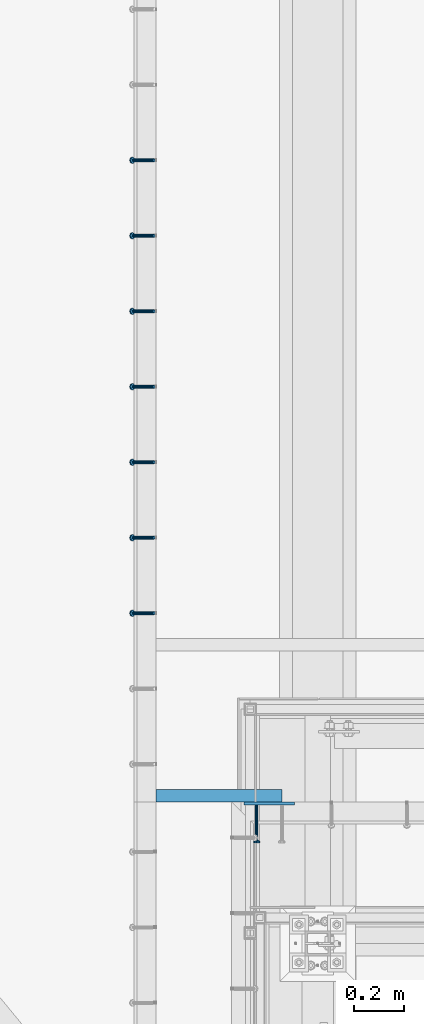
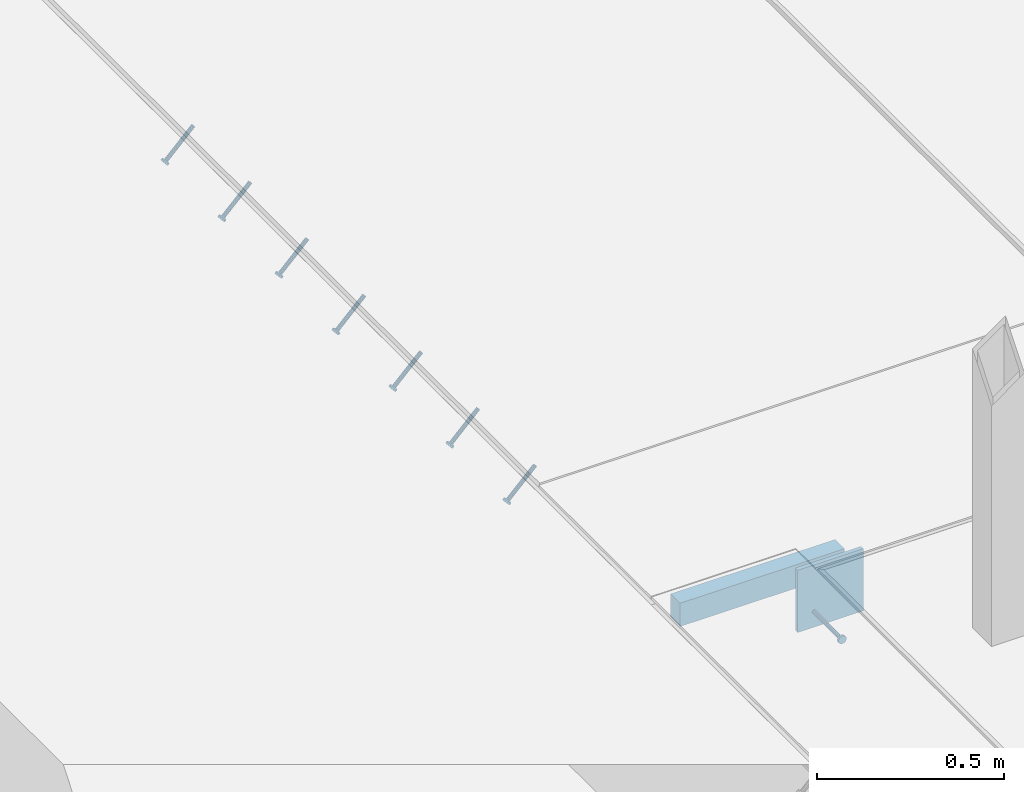
# One storey, part 2118 of 3843: 7 members, 3 beams, 3 elements without a shape of their own.
"""IFC2X3 building model written with IfcOpenShell, lengths in millimetres."""

from ifc_helpers import new_model, si_unit, frame, origin_with_axes, place, context, subcontext, project, spatial, faceted_brep, material, type_object, element, aggregate, save


model = new_model("IFC2X3")

# Units and contexts
model_context = context("Model", 3, precision=1e-05, world=origin_with_axes())
body_context = subcontext(model_context, "Body", "Model", "MODEL_VIEW")
ifc_project = project(units=[si_unit("LENGTHUNIT", "METRE", prefix="MILLI"), si_unit("AREAUNIT", "SQUARE_METRE"), si_unit("VOLUMEUNIT", "CUBIC_METRE"), si_unit("MASSUNIT", "GRAM", prefix="KILO"), si_unit("TIMEUNIT", "SECOND"), si_unit("PLANEANGLEUNIT", "RADIAN"), si_unit("SOLIDANGLEUNIT", "STERADIAN"), si_unit("THERMODYNAMICTEMPERATUREUNIT", "DEGREE_CELSIUS"), si_unit("LUMINOUSINTENSITYUNIT", "LUMEN")], contexts=[model_context])

# Site, building, storey
site_placement = place(None, origin_with_axes())
site = spatial("IfcSite", under=ifc_project, at=site_placement, CompositionType="ELEMENT")
building_placement = place(site_placement, origin_with_axes())
building = spatial("IfcBuilding", under=site, at=building_placement, Name="Undefined", CompositionType="ELEMENT")
storey_placement = place(building_placement, origin_with_axes())
storey = spatial("IfcBuildingStorey", under=building, at=storey_placement, Name="Undefined", CompositionType="ELEMENT", Elevation=0.0)

# Assembly, members
assembly_1_placement = place(storey_placement, origin_with_axes())
assembly_1 = element("IfcElementAssembly", 1, at=assembly_1_placement, inside=storey, Name="EMBED_ANGLE", AssemblyPlace="NOTDEFINED", PredefinedType="RIGID_FRAME")
ifc_material_1 = material(Name="STEEL/A108")
member_type = type_object("IfcMemberType", PredefinedType="NOTDEFINED")
member_1_placement = place(assembly_1_placement, frame((48335.3741210938, 28930.6003845215, 30446.6625), z_axis=(0.0, -1.0, 0.0), x_axis=(-0.707106781186548, 0.0, -0.707106781186548)))
member_1 = element("IfcMember", 2, at=member_1_placement, type_object=member_type, material=ifc_material_1, Name="HEADED STUD ANCHOR", context=body_context, shape_type="Brep", body=[
    faceted_brep([(7.27595761418343e-12, -3.18000006675175, 5.5), (0.0, -5.49999999998363, 3.1800000667572), (118.110000000976, -5.49999999999091, 3.1800000667572), (118.110000000983, -3.18000006675175, 5.5), (0.0, -6.3499999046162, 0.0), (118.110000000968, -6.34999990461256, 0.0), (0.0, -5.49999999998363, -3.1800000667572), (118.110000000976, -5.49999999999091, -3.1800000667572), (7.27595761418343e-12, -3.18000006675175, -5.5), (118.110000000983, -3.18000006675175, -5.5), (7.27595761418343e-12, -1.81898940354586e-12, -6.34999990463257), (118.110000000968, -1.81898940354586e-12, -6.34999990463257), (0.0, 3.18000006675175, -5.5), (118.110000000968, 3.18000006674811, -5.5), (7.27595761418343e-12, 5.49999999998363, -3.1800000667572), (118.110000000983, 5.49999999998363, -3.1800000667572), (7.27595761418343e-12, 6.3499999046162, 0.0), (118.110000000976, 6.34999990461256, 0.0), (7.27595761418343e-12, 5.49999999998363, 3.1800000667572), (118.110000000983, 5.49999999998363, 3.1800000667572), (0.0, 3.18000006675175, 5.5), (118.110000000968, 3.18000006674811, 5.5), (7.27595761418343e-12, -1.81898940354586e-12, 6.34999990463257), (118.110000000968, -1.81898940354586e-12, 6.34999990463257), (120.650000000991, -10.9899997710909, 6.34999990463257), (120.650000000998, -6.34000015257152, 10.9899997711182), (120.650000000991, -12.6999998092379, 0.0), (120.650000000991, -10.9899997710909, -6.34999990463257), (120.650000000998, -6.34000015257152, -10.9899997711182), (120.650000000991, -1.81898940354586e-12, -12.6899995803833), (120.650000000991, 6.34000015257152, -10.9899997711182), (120.650000000998, 10.9899997710909, -6.34999990463257), (120.650000000991, 12.6999998092342, 0.0), (120.650000000998, 10.9899997710909, 6.34999990463257), (120.650000000991, 6.34000015257152, 10.9899997711182), (120.650000000991, -1.81898940354586e-12, 12.6899995803833), (127.000000001048, -10.9899997710945, 6.34999990463257), (127.000000001048, -6.34000015257152, 10.9899997711182), (127.000000001048, -12.6999998092342, 0.0), (127.000000001048, -10.9899997710945, -6.34999990463257), (127.000000001048, -6.34000015257152, -10.9899997711182), (127.000000001048, 1.81898940354586e-12, -12.6899995803833), (127.000000001048, 6.34000015256788, -10.9899997711182), (127.000000001048, 10.9899997710909, -6.34999990463257), (127.000000001048, 12.6999998092379, 0.0), (127.000000001048, 10.9899997710909, 6.34999990463257), (127.000000001048, 6.34000015256788, 10.9899997711182), (127.000000001048, 1.81898940354586e-12, 12.6899995803833)], [[[0, 1, 2, 3]], [[1, 4, 5, 2]], [[4, 6, 7, 5]], [[6, 8, 9, 7]], [[8, 10, 11, 9]], [[10, 12, 13, 11]], [[12, 14, 15, 13]], [[14, 16, 17, 15]], [[16, 18, 19, 17]], [[18, 20, 21, 19]], [[20, 22, 23, 21]], [[22, 0, 3, 23]], [[22, 20, 18, 16, 14, 12, 10, 8, 6, 4, 1, 0]], [[3, 2, 24, 25]], [[2, 5, 26, 24]], [[5, 7, 27, 26]], [[7, 9, 28, 27]], [[9, 11, 29, 28]], [[11, 13, 30, 29]], [[13, 15, 31, 30]], [[15, 17, 32, 31]], [[17, 19, 33, 32]], [[19, 21, 34, 33]], [[21, 23, 35, 34]], [[23, 3, 25, 35]], [[25, 24, 36, 37]], [[24, 26, 38, 36]], [[26, 27, 39, 38]], [[27, 28, 40, 39]], [[28, 29, 41, 40]], [[29, 30, 42, 41]], [[30, 31, 43, 42]], [[31, 32, 44, 43]], [[32, 33, 45, 44]], [[33, 34, 46, 45]], [[34, 35, 47, 46]], [[35, 25, 37, 47]], [[38, 39, 40, 41, 42, 43, 44, 45, 46, 47, 37, 36]]]),
])
member_2_placement = place(assembly_1_placement, frame((48335.3741210938, 29235.4003845215, 30446.6625), z_axis=(0.0, -1.0, 0.0), x_axis=(-0.707106781186548, 0.0, -0.707106781186548)))
member_2 = element("IfcMember", 3, at=member_2_placement, type_object=member_type, material=ifc_material_1, Name="HEADED STUD ANCHOR", context=body_context, shape_type="Brep", body=[
    faceted_brep([(7.27595761418343e-12, -3.18000006675175, 5.5), (0.0, -5.49999999998363, 3.1800000667572), (118.110000000976, -5.49999999999091, 3.1800000667572), (118.110000000983, -3.18000006675175, 5.5), (0.0, -6.3499999046162, 0.0), (118.110000000968, -6.34999990461256, 0.0), (0.0, -5.49999999998363, -3.1800000667572), (118.110000000976, -5.49999999999091, -3.1800000667572), (7.27595761418343e-12, -3.18000006675175, -5.5), (118.110000000983, -3.18000006675175, -5.5), (7.27595761418343e-12, -1.81898940354586e-12, -6.34999990463257), (118.110000000968, -1.81898940354586e-12, -6.34999990463257), (0.0, 3.18000006675175, -5.5), (118.110000000968, 3.18000006674811, -5.5), (7.27595761418343e-12, 5.49999999998363, -3.1800000667572), (118.110000000983, 5.49999999998363, -3.1800000667572), (7.27595761418343e-12, 6.3499999046162, 0.0), (118.110000000976, 6.34999990461256, 0.0), (7.27595761418343e-12, 5.49999999998363, 3.1800000667572), (118.110000000983, 5.49999999998363, 3.1800000667572), (0.0, 3.18000006675175, 5.5), (118.110000000968, 3.18000006674811, 5.5), (7.27595761418343e-12, -1.81898940354586e-12, 6.34999990463257), (118.110000000968, -1.81898940354586e-12, 6.34999990463257), (120.650000000991, -10.9899997710909, 6.34999990463257), (120.650000000998, -6.34000015257152, 10.9899997711182), (120.650000000991, -12.6999998092379, 0.0), (120.650000000991, -10.9899997710909, -6.34999990463257), (120.650000000998, -6.34000015257152, -10.9899997711182), (120.650000000991, -1.81898940354586e-12, -12.6899995803833), (120.650000000991, 6.34000015257152, -10.9899997711182), (120.650000000998, 10.9899997710909, -6.34999990463257), (120.650000000991, 12.6999998092342, 0.0), (120.650000000998, 10.9899997710909, 6.34999990463257), (120.650000000991, 6.34000015257152, 10.9899997711182), (120.650000000991, -1.81898940354586e-12, 12.6899995803833), (127.000000001048, -10.9899997710945, 6.34999990463257), (127.000000001048, -6.34000015257152, 10.9899997711182), (127.000000001048, -12.6999998092342, 0.0), (127.000000001048, -10.9899997710945, -6.34999990463257), (127.000000001048, -6.34000015257152, -10.9899997711182), (127.000000001048, 1.81898940354586e-12, -12.6899995803833), (127.000000001048, 6.34000015256788, -10.9899997711182), (127.000000001048, 10.9899997710909, -6.34999990463257), (127.000000001048, 12.6999998092379, 0.0), (127.000000001048, 10.9899997710909, 6.34999990463257), (127.000000001048, 6.34000015256788, 10.9899997711182), (127.000000001048, 1.81898940354586e-12, 12.6899995803833)], [[[0, 1, 2, 3]], [[1, 4, 5, 2]], [[4, 6, 7, 5]], [[6, 8, 9, 7]], [[8, 10, 11, 9]], [[10, 12, 13, 11]], [[12, 14, 15, 13]], [[14, 16, 17, 15]], [[16, 18, 19, 17]], [[18, 20, 21, 19]], [[20, 22, 23, 21]], [[22, 0, 3, 23]], [[22, 20, 18, 16, 14, 12, 10, 8, 6, 4, 1, 0]], [[3, 2, 24, 25]], [[2, 5, 26, 24]], [[5, 7, 27, 26]], [[7, 9, 28, 27]], [[9, 11, 29, 28]], [[11, 13, 30, 29]], [[13, 15, 31, 30]], [[15, 17, 32, 31]], [[17, 19, 33, 32]], [[19, 21, 34, 33]], [[21, 23, 35, 34]], [[23, 3, 25, 35]], [[25, 24, 36, 37]], [[24, 26, 38, 36]], [[26, 27, 39, 38]], [[27, 28, 40, 39]], [[28, 29, 41, 40]], [[29, 30, 42, 41]], [[30, 31, 43, 42]], [[31, 32, 44, 43]], [[32, 33, 45, 44]], [[33, 34, 46, 45]], [[34, 35, 47, 46]], [[35, 25, 37, 47]], [[38, 39, 40, 41, 42, 43, 44, 45, 46, 47, 37, 36]]]),
])
member_3_placement = place(assembly_1_placement, frame((48335.3741210938, 29540.2003845215, 30446.6625), z_axis=(0.0, -1.0, 0.0), x_axis=(-0.707106781186548, 0.0, -0.707106781186548)))
member_3 = element("IfcMember", 4, at=member_3_placement, type_object=member_type, material=ifc_material_1, Name="HEADED STUD ANCHOR", context=body_context, shape_type="Brep", body=[
    faceted_brep([(7.27595761418343e-12, -3.18000006675175, 5.5), (0.0, -5.49999999998363, 3.1800000667572), (118.110000000976, -5.49999999999091, 3.1800000667572), (118.110000000983, -3.18000006675175, 5.5), (0.0, -6.3499999046162, 0.0), (118.110000000968, -6.34999990461256, 0.0), (0.0, -5.49999999998363, -3.1800000667572), (118.110000000976, -5.49999999999091, -3.1800000667572), (7.27595761418343e-12, -3.18000006675175, -5.5), (118.110000000983, -3.18000006675175, -5.5), (7.27595761418343e-12, -1.81898940354586e-12, -6.34999990463257), (118.110000000968, -1.81898940354586e-12, -6.34999990463257), (0.0, 3.18000006675175, -5.5), (118.110000000968, 3.18000006674811, -5.5), (7.27595761418343e-12, 5.49999999998363, -3.1800000667572), (118.110000000983, 5.49999999998363, -3.1800000667572), (7.27595761418343e-12, 6.3499999046162, 0.0), (118.110000000976, 6.34999990461256, 0.0), (7.27595761418343e-12, 5.49999999998363, 3.1800000667572), (118.110000000983, 5.49999999998363, 3.1800000667572), (0.0, 3.18000006675175, 5.5), (118.110000000968, 3.18000006674811, 5.5), (7.27595761418343e-12, -1.81898940354586e-12, 6.34999990463257), (118.110000000968, -1.81898940354586e-12, 6.34999990463257), (120.650000000991, -10.9899997710909, 6.34999990463257), (120.650000000998, -6.34000015257152, 10.9899997711182), (120.650000000991, -12.6999998092379, 0.0), (120.650000000991, -10.9899997710909, -6.34999990463257), (120.650000000998, -6.34000015257152, -10.9899997711182), (120.650000000991, -1.81898940354586e-12, -12.6899995803833), (120.650000000991, 6.34000015257152, -10.9899997711182), (120.650000000998, 10.9899997710909, -6.34999990463257), (120.650000000991, 12.6999998092342, 0.0), (120.650000000998, 10.9899997710909, 6.34999990463257), (120.650000000991, 6.34000015257152, 10.9899997711182), (120.650000000991, -1.81898940354586e-12, 12.6899995803833), (127.000000001048, -10.9899997710945, 6.34999990463257), (127.000000001048, -6.34000015257152, 10.9899997711182), (127.000000001048, -12.6999998092342, 0.0), (127.000000001048, -10.9899997710945, -6.34999990463257), (127.000000001048, -6.34000015257152, -10.9899997711182), (127.000000001048, 1.81898940354586e-12, -12.6899995803833), (127.000000001048, 6.34000015256788, -10.9899997711182), (127.000000001048, 10.9899997710909, -6.34999990463257), (127.000000001048, 12.6999998092379, 0.0), (127.000000001048, 10.9899997710909, 6.34999990463257), (127.000000001048, 6.34000015256788, 10.9899997711182), (127.000000001048, 1.81898940354586e-12, 12.6899995803833)], [[[0, 1, 2, 3]], [[1, 4, 5, 2]], [[4, 6, 7, 5]], [[6, 8, 9, 7]], [[8, 10, 11, 9]], [[10, 12, 13, 11]], [[12, 14, 15, 13]], [[14, 16, 17, 15]], [[16, 18, 19, 17]], [[18, 20, 21, 19]], [[20, 22, 23, 21]], [[22, 0, 3, 23]], [[22, 20, 18, 16, 14, 12, 10, 8, 6, 4, 1, 0]], [[3, 2, 24, 25]], [[2, 5, 26, 24]], [[5, 7, 27, 26]], [[7, 9, 28, 27]], [[9, 11, 29, 28]], [[11, 13, 30, 29]], [[13, 15, 31, 30]], [[15, 17, 32, 31]], [[17, 19, 33, 32]], [[19, 21, 34, 33]], [[21, 23, 35, 34]], [[23, 3, 25, 35]], [[25, 24, 36, 37]], [[24, 26, 38, 36]], [[26, 27, 39, 38]], [[27, 28, 40, 39]], [[28, 29, 41, 40]], [[29, 30, 42, 41]], [[30, 31, 43, 42]], [[31, 32, 44, 43]], [[32, 33, 45, 44]], [[33, 34, 46, 45]], [[34, 35, 47, 46]], [[35, 25, 37, 47]], [[38, 39, 40, 41, 42, 43, 44, 45, 46, 47, 37, 36]]]),
])
member_4_placement = place(assembly_1_placement, frame((48335.3741210938, 29845.0003845215, 30446.6625), z_axis=(0.0, -1.0, 0.0), x_axis=(-0.707106781186548, 0.0, -0.707106781186548)))
member_4 = element("IfcMember", 5, at=member_4_placement, type_object=member_type, material=ifc_material_1, Name="HEADED STUD ANCHOR", context=body_context, shape_type="Brep", body=[
    faceted_brep([(7.27595761418343e-12, -3.18000006675175, 5.5), (0.0, -5.49999999998363, 3.1800000667572), (118.110000000976, -5.49999999999091, 3.1800000667572), (118.110000000983, -3.18000006675175, 5.5), (0.0, -6.3499999046162, 0.0), (118.110000000968, -6.34999990461256, 0.0), (0.0, -5.49999999998363, -3.1800000667572), (118.110000000976, -5.49999999999091, -3.1800000667572), (7.27595761418343e-12, -3.18000006675175, -5.5), (118.110000000983, -3.18000006675175, -5.5), (7.27595761418343e-12, -1.81898940354586e-12, -6.34999990463257), (118.110000000968, -1.81898940354586e-12, -6.34999990463257), (0.0, 3.18000006675175, -5.5), (118.110000000968, 3.18000006674811, -5.5), (7.27595761418343e-12, 5.49999999998363, -3.1800000667572), (118.110000000983, 5.49999999998363, -3.1800000667572), (7.27595761418343e-12, 6.3499999046162, 0.0), (118.110000000976, 6.34999990461256, 0.0), (7.27595761418343e-12, 5.49999999998363, 3.1800000667572), (118.110000000983, 5.49999999998363, 3.1800000667572), (0.0, 3.18000006675175, 5.5), (118.110000000968, 3.18000006674811, 5.5), (7.27595761418343e-12, -1.81898940354586e-12, 6.34999990463257), (118.110000000968, -1.81898940354586e-12, 6.34999990463257), (120.650000000991, -10.9899997710909, 6.34999990463257), (120.650000000998, -6.34000015257152, 10.9899997711182), (120.650000000991, -12.6999998092379, 0.0), (120.650000000991, -10.9899997710909, -6.34999990463257), (120.650000000998, -6.34000015257152, -10.9899997711182), (120.650000000991, -1.81898940354586e-12, -12.6899995803833), (120.650000000991, 6.34000015257152, -10.9899997711182), (120.650000000998, 10.9899997710909, -6.34999990463257), (120.650000000991, 12.6999998092342, 0.0), (120.650000000998, 10.9899997710909, 6.34999990463257), (120.650000000991, 6.34000015257152, 10.9899997711182), (120.650000000991, -1.81898940354586e-12, 12.6899995803833), (127.000000001048, -10.9899997710945, 6.34999990463257), (127.000000001048, -6.34000015257152, 10.9899997711182), (127.000000001048, -12.6999998092342, 0.0), (127.000000001048, -10.9899997710945, -6.34999990463257), (127.000000001048, -6.34000015257152, -10.9899997711182), (127.000000001048, 1.81898940354586e-12, -12.6899995803833), (127.000000001048, 6.34000015256788, -10.9899997711182), (127.000000001048, 10.9899997710909, -6.34999990463257), (127.000000001048, 12.6999998092379, 0.0), (127.000000001048, 10.9899997710909, 6.34999990463257), (127.000000001048, 6.34000015256788, 10.9899997711182), (127.000000001048, 1.81898940354586e-12, 12.6899995803833)], [[[0, 1, 2, 3]], [[1, 4, 5, 2]], [[4, 6, 7, 5]], [[6, 8, 9, 7]], [[8, 10, 11, 9]], [[10, 12, 13, 11]], [[12, 14, 15, 13]], [[14, 16, 17, 15]], [[16, 18, 19, 17]], [[18, 20, 21, 19]], [[20, 22, 23, 21]], [[22, 0, 3, 23]], [[22, 20, 18, 16, 14, 12, 10, 8, 6, 4, 1, 0]], [[3, 2, 24, 25]], [[2, 5, 26, 24]], [[5, 7, 27, 26]], [[7, 9, 28, 27]], [[9, 11, 29, 28]], [[11, 13, 30, 29]], [[13, 15, 31, 30]], [[15, 17, 32, 31]], [[17, 19, 33, 32]], [[19, 21, 34, 33]], [[21, 23, 35, 34]], [[23, 3, 25, 35]], [[25, 24, 36, 37]], [[24, 26, 38, 36]], [[26, 27, 39, 38]], [[27, 28, 40, 39]], [[28, 29, 41, 40]], [[29, 30, 42, 41]], [[30, 31, 43, 42]], [[31, 32, 44, 43]], [[32, 33, 45, 44]], [[33, 34, 46, 45]], [[34, 35, 47, 46]], [[35, 25, 37, 47]], [[38, 39, 40, 41, 42, 43, 44, 45, 46, 47, 37, 36]]]),
])
member_5_placement = place(assembly_1_placement, frame((48335.3741210938, 30149.8003845215, 30446.6625), z_axis=(0.0, -1.0, 0.0), x_axis=(-0.707106781186548, 0.0, -0.707106781186548)))
member_5 = element("IfcMember", 6, at=member_5_placement, type_object=member_type, material=ifc_material_1, Name="HEADED STUD ANCHOR", context=body_context, shape_type="Brep", body=[
    faceted_brep([(7.27595761418343e-12, -3.18000006675175, 5.5), (0.0, -5.49999999998363, 3.1800000667572), (118.110000000976, -5.49999999999091, 3.1800000667572), (118.110000000983, -3.18000006675175, 5.5), (0.0, -6.3499999046162, 0.0), (118.110000000968, -6.34999990461256, 0.0), (0.0, -5.49999999998363, -3.1800000667572), (118.110000000976, -5.49999999999091, -3.1800000667572), (7.27595761418343e-12, -3.18000006675175, -5.5), (118.110000000983, -3.18000006675175, -5.5), (7.27595761418343e-12, -1.81898940354586e-12, -6.34999990463257), (118.110000000968, -1.81898940354586e-12, -6.34999990463257), (0.0, 3.18000006675175, -5.5), (118.110000000968, 3.18000006674811, -5.5), (7.27595761418343e-12, 5.49999999998363, -3.1800000667572), (118.110000000983, 5.49999999998363, -3.1800000667572), (7.27595761418343e-12, 6.3499999046162, 0.0), (118.110000000976, 6.34999990461256, 0.0), (7.27595761418343e-12, 5.49999999998363, 3.1800000667572), (118.110000000983, 5.49999999998363, 3.1800000667572), (0.0, 3.18000006675175, 5.5), (118.110000000968, 3.18000006674811, 5.5), (7.27595761418343e-12, -1.81898940354586e-12, 6.34999990463257), (118.110000000968, -1.81898940354586e-12, 6.34999990463257), (120.650000000991, -10.9899997710909, 6.34999990463257), (120.650000000998, -6.34000015257152, 10.9899997711182), (120.650000000991, -12.6999998092379, 0.0), (120.650000000991, -10.9899997710909, -6.34999990463257), (120.650000000998, -6.34000015257152, -10.9899997711182), (120.650000000991, -1.81898940354586e-12, -12.6899995803833), (120.650000000991, 6.34000015257152, -10.9899997711182), (120.650000000998, 10.9899997710909, -6.34999990463257), (120.650000000991, 12.6999998092342, 0.0), (120.650000000998, 10.9899997710909, 6.34999990463257), (120.650000000991, 6.34000015257152, 10.9899997711182), (120.650000000991, -1.81898940354586e-12, 12.6899995803833), (127.000000001048, -10.9899997710945, 6.34999990463257), (127.000000001048, -6.34000015257152, 10.9899997711182), (127.000000001048, -12.6999998092342, 0.0), (127.000000001048, -10.9899997710945, -6.34999990463257), (127.000000001048, -6.34000015257152, -10.9899997711182), (127.000000001048, 1.81898940354586e-12, -12.6899995803833), (127.000000001048, 6.34000015256788, -10.9899997711182), (127.000000001048, 10.9899997710909, -6.34999990463257), (127.000000001048, 12.6999998092379, 0.0), (127.000000001048, 10.9899997710909, 6.34999990463257), (127.000000001048, 6.34000015256788, 10.9899997711182), (127.000000001048, 1.81898940354586e-12, 12.6899995803833)], [[[0, 1, 2, 3]], [[1, 4, 5, 2]], [[4, 6, 7, 5]], [[6, 8, 9, 7]], [[8, 10, 11, 9]], [[10, 12, 13, 11]], [[12, 14, 15, 13]], [[14, 16, 17, 15]], [[16, 18, 19, 17]], [[18, 20, 21, 19]], [[20, 22, 23, 21]], [[22, 0, 3, 23]], [[22, 20, 18, 16, 14, 12, 10, 8, 6, 4, 1, 0]], [[3, 2, 24, 25]], [[2, 5, 26, 24]], [[5, 7, 27, 26]], [[7, 9, 28, 27]], [[9, 11, 29, 28]], [[11, 13, 30, 29]], [[13, 15, 31, 30]], [[15, 17, 32, 31]], [[17, 19, 33, 32]], [[19, 21, 34, 33]], [[21, 23, 35, 34]], [[23, 3, 25, 35]], [[25, 24, 36, 37]], [[24, 26, 38, 36]], [[26, 27, 39, 38]], [[27, 28, 40, 39]], [[28, 29, 41, 40]], [[29, 30, 42, 41]], [[30, 31, 43, 42]], [[31, 32, 44, 43]], [[32, 33, 45, 44]], [[33, 34, 46, 45]], [[34, 35, 47, 46]], [[35, 25, 37, 47]], [[38, 39, 40, 41, 42, 43, 44, 45, 46, 47, 37, 36]]]),
])
member_6_placement = place(assembly_1_placement, frame((48335.3741210938, 30454.6003845215, 30446.6625), z_axis=(0.0, -1.0, 0.0), x_axis=(-0.707106781186548, 0.0, -0.707106781186548)))
member_6 = element("IfcMember", 7, at=member_6_placement, type_object=member_type, material=ifc_material_1, Name="HEADED STUD ANCHOR", context=body_context, shape_type="Brep", body=[
    faceted_brep([(7.27595761418343e-12, -3.18000006675175, 5.5), (0.0, -5.49999999998363, 3.1800000667572), (118.110000000976, -5.49999999999091, 3.1800000667572), (118.110000000983, -3.18000006675175, 5.5), (0.0, -6.3499999046162, 0.0), (118.110000000968, -6.34999990461256, 0.0), (0.0, -5.49999999998363, -3.1800000667572), (118.110000000976, -5.49999999999091, -3.1800000667572), (7.27595761418343e-12, -3.18000006675175, -5.5), (118.110000000983, -3.18000006675175, -5.5), (7.27595761418343e-12, -1.81898940354586e-12, -6.34999990463257), (118.110000000968, -1.81898940354586e-12, -6.34999990463257), (0.0, 3.18000006675175, -5.5), (118.110000000968, 3.18000006674811, -5.5), (7.27595761418343e-12, 5.49999999998363, -3.1800000667572), (118.110000000983, 5.49999999998363, -3.1800000667572), (7.27595761418343e-12, 6.3499999046162, 0.0), (118.110000000976, 6.34999990461256, 0.0), (7.27595761418343e-12, 5.49999999998363, 3.1800000667572), (118.110000000983, 5.49999999998363, 3.1800000667572), (0.0, 3.18000006675175, 5.5), (118.110000000968, 3.18000006674811, 5.5), (7.27595761418343e-12, -1.81898940354586e-12, 6.34999990463257), (118.110000000968, -1.81898940354586e-12, 6.34999990463257), (120.650000000991, -10.9899997710909, 6.34999990463257), (120.650000000998, -6.34000015257152, 10.9899997711182), (120.650000000991, -12.6999998092379, 0.0), (120.650000000991, -10.9899997710909, -6.34999990463257), (120.650000000998, -6.34000015257152, -10.9899997711182), (120.650000000991, -1.81898940354586e-12, -12.6899995803833), (120.650000000991, 6.34000015257152, -10.9899997711182), (120.650000000998, 10.9899997710909, -6.34999990463257), (120.650000000991, 12.6999998092342, 0.0), (120.650000000998, 10.9899997710909, 6.34999990463257), (120.650000000991, 6.34000015257152, 10.9899997711182), (120.650000000991, -1.81898940354586e-12, 12.6899995803833), (127.000000001048, -10.9899997710945, 6.34999990463257), (127.000000001048, -6.34000015257152, 10.9899997711182), (127.000000001048, -12.6999998092342, 0.0), (127.000000001048, -10.9899997710945, -6.34999990463257), (127.000000001048, -6.34000015257152, -10.9899997711182), (127.000000001048, 1.81898940354586e-12, -12.6899995803833), (127.000000001048, 6.34000015256788, -10.9899997711182), (127.000000001048, 10.9899997710909, -6.34999990463257), (127.000000001048, 12.6999998092379, 0.0), (127.000000001048, 10.9899997710909, 6.34999990463257), (127.000000001048, 6.34000015256788, 10.9899997711182), (127.000000001048, 1.81898940354586e-12, 12.6899995803833)], [[[0, 1, 2, 3]], [[1, 4, 5, 2]], [[4, 6, 7, 5]], [[6, 8, 9, 7]], [[8, 10, 11, 9]], [[10, 12, 13, 11]], [[12, 14, 15, 13]], [[14, 16, 17, 15]], [[16, 18, 19, 17]], [[18, 20, 21, 19]], [[20, 22, 23, 21]], [[22, 0, 3, 23]], [[22, 20, 18, 16, 14, 12, 10, 8, 6, 4, 1, 0]], [[3, 2, 24, 25]], [[2, 5, 26, 24]], [[5, 7, 27, 26]], [[7, 9, 28, 27]], [[9, 11, 29, 28]], [[11, 13, 30, 29]], [[13, 15, 31, 30]], [[15, 17, 32, 31]], [[17, 19, 33, 32]], [[19, 21, 34, 33]], [[21, 23, 35, 34]], [[23, 3, 25, 35]], [[25, 24, 36, 37]], [[24, 26, 38, 36]], [[26, 27, 39, 38]], [[27, 28, 40, 39]], [[28, 29, 41, 40]], [[29, 30, 42, 41]], [[30, 31, 43, 42]], [[31, 32, 44, 43]], [[32, 33, 45, 44]], [[33, 34, 46, 45]], [[34, 35, 47, 46]], [[35, 25, 37, 47]], [[38, 39, 40, 41, 42, 43, 44, 45, 46, 47, 37, 36]]]),
])
member_7_placement = place(assembly_1_placement, frame((48335.3741210938, 30759.4003845215, 30446.6625), z_axis=(0.0, -1.0, 0.0), x_axis=(-0.707106781186548, 0.0, -0.707106781186548)))
member_7 = element("IfcMember", 8, at=member_7_placement, type_object=member_type, material=ifc_material_1, Name="HEADED STUD ANCHOR", context=body_context, shape_type="Brep", body=[
    faceted_brep([(7.27595761418343e-12, -3.18000006675175, 5.5), (0.0, -5.49999999998363, 3.1800000667572), (118.110000000976, -5.49999999999091, 3.1800000667572), (118.110000000983, -3.18000006675175, 5.5), (0.0, -6.3499999046162, 0.0), (118.110000000968, -6.34999990461256, 0.0), (0.0, -5.49999999998363, -3.1800000667572), (118.110000000976, -5.49999999999091, -3.1800000667572), (7.27595761418343e-12, -3.18000006675175, -5.5), (118.110000000983, -3.18000006675175, -5.5), (7.27595761418343e-12, -1.81898940354586e-12, -6.34999990463257), (118.110000000968, -1.81898940354586e-12, -6.34999990463257), (0.0, 3.18000006675175, -5.5), (118.110000000968, 3.18000006674811, -5.5), (7.27595761418343e-12, 5.49999999998363, -3.1800000667572), (118.110000000983, 5.49999999998363, -3.1800000667572), (7.27595761418343e-12, 6.3499999046162, 0.0), (118.110000000976, 6.34999990461256, 0.0), (7.27595761418343e-12, 5.49999999998363, 3.1800000667572), (118.110000000983, 5.49999999998363, 3.1800000667572), (0.0, 3.18000006675175, 5.5), (118.110000000968, 3.18000006674811, 5.5), (7.27595761418343e-12, -1.81898940354586e-12, 6.34999990463257), (118.110000000968, -1.81898940354586e-12, 6.34999990463257), (120.650000000991, -10.9899997710909, 6.34999990463257), (120.650000000998, -6.34000015257152, 10.9899997711182), (120.650000000991, -12.6999998092379, 0.0), (120.650000000991, -10.9899997710909, -6.34999990463257), (120.650000000998, -6.34000015257152, -10.9899997711182), (120.650000000991, -1.81898940354586e-12, -12.6899995803833), (120.650000000991, 6.34000015257152, -10.9899997711182), (120.650000000998, 10.9899997710909, -6.34999990463257), (120.650000000991, 12.6999998092342, 0.0), (120.650000000998, 10.9899997710909, 6.34999990463257), (120.650000000991, 6.34000015257152, 10.9899997711182), (120.650000000991, -1.81898940354586e-12, 12.6899995803833), (127.000000001048, -10.9899997710945, 6.34999990463257), (127.000000001048, -6.34000015257152, 10.9899997711182), (127.000000001048, -12.6999998092342, 0.0), (127.000000001048, -10.9899997710945, -6.34999990463257), (127.000000001048, -6.34000015257152, -10.9899997711182), (127.000000001048, 1.81898940354586e-12, -12.6899995803833), (127.000000001048, 6.34000015256788, -10.9899997711182), (127.000000001048, 10.9899997710909, -6.34999990463257), (127.000000001048, 12.6999998092379, 0.0), (127.000000001048, 10.9899997710909, 6.34999990463257), (127.000000001048, 6.34000015256788, 10.9899997711182), (127.000000001048, 1.81898940354586e-12, 12.6899995803833)], [[[0, 1, 2, 3]], [[1, 4, 5, 2]], [[4, 6, 7, 5]], [[6, 8, 9, 7]], [[8, 10, 11, 9]], [[10, 12, 13, 11]], [[12, 14, 15, 13]], [[14, 16, 17, 15]], [[16, 18, 19, 17]], [[18, 20, 21, 19]], [[20, 22, 23, 21]], [[22, 0, 3, 23]], [[22, 20, 18, 16, 14, 12, 10, 8, 6, 4, 1, 0]], [[3, 2, 24, 25]], [[2, 5, 26, 24]], [[5, 7, 27, 26]], [[7, 9, 28, 27]], [[9, 11, 29, 28]], [[11, 13, 30, 29]], [[13, 15, 31, 30]], [[15, 17, 32, 31]], [[17, 19, 33, 32]], [[19, 21, 34, 33]], [[21, 23, 35, 34]], [[23, 3, 25, 35]], [[25, 24, 36, 37]], [[24, 26, 38, 36]], [[26, 27, 39, 38]], [[27, 28, 40, 39]], [[28, 29, 41, 40]], [[29, 30, 42, 41]], [[30, 31, 43, 42]], [[31, 32, 44, 43]], [[32, 33, 45, 44]], [[33, 34, 46, 45]], [[34, 35, 47, 46]], [[35, 25, 37, 47]], [[38, 39, 40, 41, 42, 43, 44, 45, 46, 47, 37, 36]]]),
])
aggregate(assembly_1, [member_1, member_2, member_3, member_4, member_5, member_6, member_7])

# Assembly, beams
assembly_2_placement = place(storey_placement, origin_with_axes())
assembly_2 = element("IfcElementAssembly", 9, at=assembly_2_placement, inside=storey, Name="EMBED PLATE", AssemblyPlace="NOTDEFINED", PredefinedType="RIGID_FRAME")
ifc_material_2 = material(Name="STEEL/A36")
beam_type_1 = type_object("IfcBeamType", PredefinedType="NOTDEFINED")
beam_1_placement = place(assembly_2_placement, frame((48800.512, 28162.25, 30445.075), z_axis=(-1.0, 0.0, 0.0), x_axis=(0.0, 0.0, -1.0)))
beam_1 = element("IfcBeam", 10, at=beam_1_placement, type_object=beam_type_1, material=ifc_material_2, Name="EMBED PLATE", context=body_context, shape_type="Brep", body=[
    faceted_brep([(1.74622982740402e-10, 6.35000000000582, -101.600000000195), (-1.67347025126219e-10, 6.35000000000582, 101.600000000151), (203.200000000001, 6.35000000000582, 101.599999999999), (203.200000000001, 6.35000000000582, -101.599999999999), (-1.67347025126219e-10, -6.35000000000582, 101.600000000151), (203.200000000001, -6.35000000000582, 101.599999999999), (1.74622982740402e-10, -6.35000000000582, -101.600000000195), (203.200000000001, -6.35000000000582, -101.599999999999)], [[[0, 1, 2, 3]], [[1, 4, 5, 2]], [[4, 6, 7, 5]], [[6, 0, 3, 7]], [[5, 7, 3, 2]], [[6, 4, 1, 0]]]),
])
beam_type_2 = type_object("IfcBeamType", PredefinedType="NOTDEFINED")
beam_2_placement = place(assembly_2_placement, frame((48749.712, 28155.9, 30292.675), z_axis=(1.0, 0.0, 0.0), x_axis=(0.0, -1.0, 0.0)))
beam_2 = element("IfcBeam", 11, at=beam_2_placement, type_object=beam_type_2, material=ifc_material_1, Name="HEADED STUD ANCHOR", context=body_context, shape_type="Brep", body=[
    faceted_brep([(7.27595761418343e-12, -3.18000006675175, 5.5), (0.0, -5.49999999998363, 3.1800000667572), (141.731999999989, -5.5, 3.1800000667572), (141.731999999989, -3.1800000667572, 5.5), (0.0, -6.3499999046162, 0.0), (141.731999999989, -6.34999990463257, 0.0), (0.0, -5.49999999998363, -3.1800000667572), (141.731999999989, -5.5, -3.1800000667572), (7.27595761418343e-12, -3.18000006675175, -5.5), (141.731999999989, -3.1800000667572, -5.5), (7.27595761418343e-12, -1.81898940354586e-12, -6.34999990463257), (141.731999999989, 0.0, -6.34999990463257), (0.0, 3.18000006675175, -5.5), (141.731999999989, 3.1800000667572, -5.5), (7.27595761418343e-12, 5.49999999998363, -3.1800000667572), (141.731999999989, 5.5, -3.1800000667572), (7.27595761418343e-12, 6.3499999046162, 0.0), (141.731999999989, 6.34999990463257, 0.0), (7.27595761418343e-12, 5.49999999998363, 3.1800000667572), (141.731999999989, 5.5, 3.1800000667572), (0.0, 3.18000006675175, 5.5), (141.731999999989, 3.1800000667572, 5.5), (7.27595761418343e-12, -1.81898940354586e-12, 6.34999990463257), (141.731999999989, 0.0, 6.34999990463257), (144.779999999999, -10.9899997711182, 6.34999990463257), (144.779999999999, -6.34000015258789, 10.9899997711182), (144.779999999999, -12.6999998092651, 0.0), (144.779999999999, -10.9899997711182, -6.34999990463257), (144.779999999999, -6.34000015258789, -10.9899997711182), (144.779999999999, 0.0, -12.6899995803833), (144.779999999999, 6.34000015258789, -10.9899997711182), (144.779999999999, 10.9899997711182, -6.34999990463257), (144.779999999999, 12.6999998092651, 0.0), (144.779999999999, 10.9899997711182, 6.34999990463257), (144.779999999999, 6.34000015258789, 10.9899997711182), (144.779999999999, 0.0, 12.6899995803833), (152.399999999994, -10.9899997711182, 6.34999990463257), (152.399999999994, -6.34000015258789, 10.9899997711182), (152.399999999994, -12.6999998092651, 0.0), (152.399999999994, -10.9899997711182, -6.34999990463257), (152.399999999994, -6.34000015258789, -10.9899997711182), (152.399999999994, 0.0, -12.6899995803833), (152.399999999994, 6.34000015258789, -10.9899997711182), (152.399999999994, 10.9899997711182, -6.34999990463257), (152.399999999994, 12.6999998092651, 0.0), (152.399999999994, 10.9899997711182, 6.34999990463257), (152.399999999994, 6.34000015258789, 10.9899997711182), (152.399999999994, 0.0, 12.6899995803833)], [[[0, 1, 2, 3]], [[1, 4, 5, 2]], [[4, 6, 7, 5]], [[6, 8, 9, 7]], [[8, 10, 11, 9]], [[10, 12, 13, 11]], [[12, 14, 15, 13]], [[14, 16, 17, 15]], [[16, 18, 19, 17]], [[18, 20, 21, 19]], [[20, 22, 23, 21]], [[22, 0, 3, 23]], [[22, 20, 18, 16, 14, 12, 10, 8, 6, 4, 1, 0]], [[3, 2, 24, 25]], [[2, 5, 26, 24]], [[5, 7, 27, 26]], [[7, 9, 28, 27]], [[9, 11, 29, 28]], [[11, 13, 30, 29]], [[13, 15, 31, 30]], [[15, 17, 32, 31]], [[17, 19, 33, 32]], [[19, 21, 34, 33]], [[21, 23, 35, 34]], [[23, 3, 25, 35]], [[25, 24, 36, 37]], [[24, 26, 38, 36]], [[26, 27, 39, 38]], [[27, 28, 40, 39]], [[28, 29, 41, 40]], [[29, 30, 42, 41]], [[30, 31, 43, 42]], [[31, 32, 44, 43]], [[32, 33, 45, 44]], [[33, 34, 46, 45]], [[34, 35, 47, 46]], [[35, 25, 37, 47]], [[38, 39, 40, 41, 42, 43, 44, 45, 46, 47, 37, 36]]]),
])
aggregate(assembly_2, [beam_2, beam_1])

# Assembly, beam
assembly_3_placement = place(storey_placement, origin_with_axes())
assembly_3 = element("IfcElementAssembly", 12, at=assembly_3_placement, inside=storey, Name="COVER PLATE", AssemblyPlace="NOTDEFINED", PredefinedType="RIGID_FRAME")
beam_type_3 = type_object("IfcBeamType", PredefinedType="NOTDEFINED")
beam_3_placement = place(assembly_3_placement, frame((48343.3119423828, 28194.0, 30416.5), z_axis=(0.0, 0.0, 1.0), x_axis=(1.0, 0.0, 0.0)))
beam_3 = element("IfcBeam", 13, at=beam_3_placement, type_object=beam_type_3, material=ifc_material_2, Name="COVER PLATE", context=body_context, shape_type="Brep", body=[
    faceted_brep([(0.0, 25.4000000000015, -38.0999999999985), (0.0, 25.4000000000015, 38.0999999999985), (508.000057618301, 25.4000000002234, 38.0999999999985), (508.000057618301, 25.4000000002234, -38.0999999999985), (0.0, -25.4000000000015, 38.0999999999985), (508.000057618337, -25.3999999997068, 38.0999999999985), (0.0, -25.4000000000015, -38.0999999999985), (508.000057618337, -25.3999999997068, -38.0999999999985)], [[[0, 1, 2, 3]], [[1, 4, 5, 2]], [[4, 6, 7, 5]], [[6, 0, 3, 7]], [[5, 7, 3, 2]], [[6, 4, 1, 0]]]),
])
aggregate(assembly_3, [beam_3])

save(model, "model.ifc")
